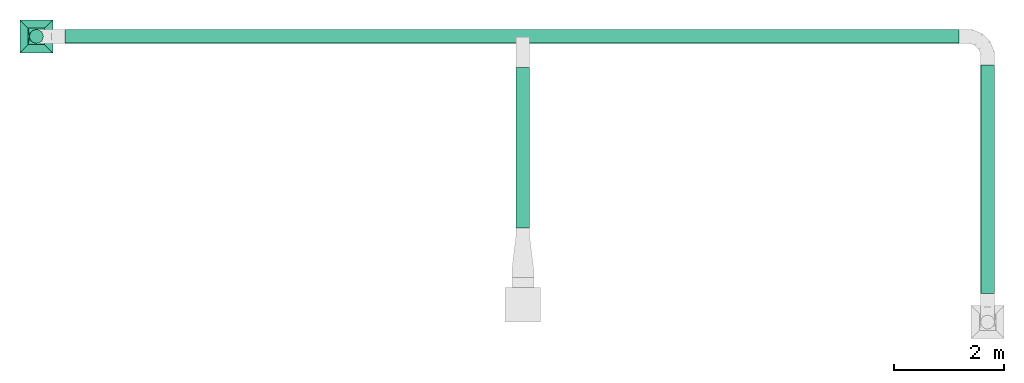
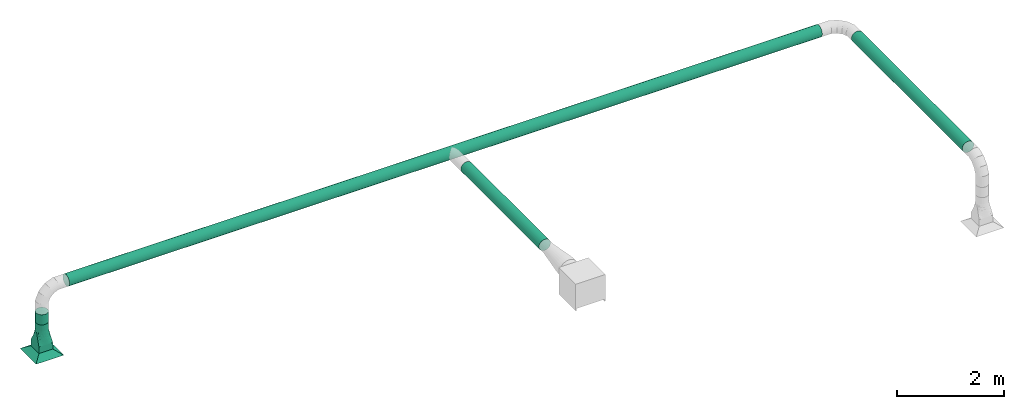
# One storey, part 1 of 6: 4 flow segments, 1 flow fitting, 1 flow terminal.
"""IFC2X3 building model written with IfcOpenShell, lengths in metres."""

from ifc_helpers import new_model, entity, si_unit, converted_unit, derived_unit, direction, frame, frame_2d, origin, origin_2d_with_axis, place, context, subcontext, project, spatial, circle, extrude, faceted_brep, source, transform, mapped, type_object, type_shapes, element, save


model = new_model("IFC2X3")

# Units and contexts
model_context = context("Model", 3, precision=1e-05, world=origin(), true_north=direction((6.12303176911189e-17, 1.0)))
body_context = subcontext(model_context, "Body", "Model", "MODEL_VIEW")
ifc_project = project(units=[si_unit("LENGTHUNIT", "METRE"), si_unit("AREAUNIT", "SQUARE_METRE"), si_unit("VOLUMEUNIT", "CUBIC_METRE"), converted_unit("PLANEANGLEUNIT", "DEGREE", entity("IfcRatioMeasure", 0.0174532925199433), si_unit("PLANEANGLEUNIT", "RADIAN"), dimensions=[0, 0, 0, 0, 0, 0, 0]), si_unit("MASSUNIT", "GRAM", prefix="KILO"), derived_unit("MASSDENSITYUNIT", [(si_unit("MASSUNIT", "GRAM", prefix="KILO"), 1), (si_unit("LENGTHUNIT", "METRE"), -3)]), si_unit("TIMEUNIT", "SECOND"), si_unit("FREQUENCYUNIT", "HERTZ"), si_unit("THERMODYNAMICTEMPERATUREUNIT", "DEGREE_CELSIUS"), derived_unit("THERMALTRANSMITTANCEUNIT", [(si_unit("MASSUNIT", "GRAM", prefix="KILO"), 1), (si_unit("THERMODYNAMICTEMPERATUREUNIT", "KELVIN"), -1), (si_unit("TIMEUNIT", "SECOND"), -3)]), derived_unit("VOLUMETRICFLOWRATEUNIT", [(si_unit("LENGTHUNIT", "METRE"), 3), (si_unit("TIMEUNIT", "SECOND"), -1)]), si_unit("ELECTRICCURRENTUNIT", "AMPERE"), si_unit("ELECTRICVOLTAGEUNIT", "VOLT"), si_unit("POWERUNIT", "WATT"), si_unit("FORCEUNIT", "NEWTON", prefix="KILO"), si_unit("ILLUMINANCEUNIT", "LUX"), si_unit("LUMINOUSFLUXUNIT", "LUMEN"), si_unit("LUMINOUSINTENSITYUNIT", "CANDELA"), derived_unit("USERDEFINED", [(si_unit("MASSUNIT", "GRAM", prefix="KILO"), -1), (si_unit("LENGTHUNIT", "METRE"), -2), (si_unit("TIMEUNIT", "SECOND"), 3), (si_unit("LUMINOUSFLUXUNIT", "LUMEN"), 1)]), derived_unit("LINEARVELOCITYUNIT", [(si_unit("LENGTHUNIT", "METRE"), 1), (si_unit("TIMEUNIT", "SECOND"), -1)]), si_unit("PRESSUREUNIT", "PASCAL"), derived_unit("USERDEFINED", [(si_unit("LENGTHUNIT", "METRE"), -2), (si_unit("MASSUNIT", "GRAM", prefix="KILO"), 1), (si_unit("TIMEUNIT", "SECOND"), -2)])], contexts=[model_context])

# Site, building, storey
site_placement = place(None, origin())
site = spatial("IfcSite", under=ifc_project, at=site_placement, CompositionType="ELEMENT")
building_placement = place(site_placement, origin())
building = spatial("IfcBuilding", under=site, at=building_placement, CompositionType="ELEMENT")
storey_placement = place(building_placement, origin())
storey = spatial("IfcBuildingStorey", under=building, at=storey_placement, Name="1 - RDC", CompositionType="ELEMENT", Elevation=1.94210219716249e-13)

# Flow terminal
air_terminal_type = type_object("IfcAirTerminalType", PredefinedType="NOTDEFINED")
shared_shape_1 = source(origin(), body_context, "Body", "Brep", [
    faceted_brep([(0.15, 0.15, 0.1016), (-0.15, 0.15, 0.1016), (-0.15, -0.15, 0.1016), (0.15, -0.15, 0.1016), (0.3, 0.3, 0.0), (0.3, -0.3, 0.0), (-0.3, -0.3, 0.0), (-0.3, 0.3, 0.0)], [[[0, 1, 2, 3]], [[4, 5, 6, 7]], [[4, 7, 1, 0]], [[7, 6, 2, 1]], [[6, 5, 3, 2]], [[5, 4, 0, 3]]]),
])
type_shapes(air_terminal_type, [shared_shape_1])
flow_terminal_placement = place(storey_placement, frame((-3.07727852654554, 0.822480211210849, 2.5)))
element("IfcFlowTerminal", 1, at=flow_terminal_placement, inside=storey, type_object=air_terminal_type, context=body_context, shape_type="MappedRepresentation", body=[
    mapped(shared_shape_1, transform((0.0, 0.0, 0.0), scale=1.0)),
])

# Flow segments
duct_segment_type = type_object("IfcDuctSegmentType", PredefinedType="NOTDEFINED")
flow_segment_1_placement = place(storey_placement, origin())
element("IfcFlowSegment", 2, at=flow_segment_1_placement, inside=storey, type_object=duct_segment_type, context=body_context, shape_type="SweptSolid", body=[
    extrude(circle(Radius=0.125, at=frame_2d((0.0, -1.35358391162299e-16), x_axis=(1.0, 0.0))), frame((-3.07727852654554, 0.822480211210858, 3.2016), z_axis=(0.0, 0.0, 1.0), x_axis=(-1.0, 0.0, 0.0)), (0.0, 0.0, 1.0), 0.232399999999998),
])
flow_segment_2_placement = place(storey_placement, origin())
element("IfcFlowSegment", 3, at=flow_segment_2_placement, inside=storey, type_object=duct_segment_type, context=body_context, shape_type="SweptSolid", body=[
    extrude(circle(Radius=0.125, at=origin_2d_with_axis()), frame((14.2727214734544, -3.8625197887892, 3.959), z_axis=(0.0, 1.0, 0.0), x_axis=(1.0, 0.0, 0.0)), (0.0, 0.0, 1.0), 4.16000000000005),
])
flow_segment_3_placement = place(storey_placement, origin())
element("IfcFlowSegment", 4, at=flow_segment_3_placement, inside=storey, type_object=duct_segment_type, context=body_context, shape_type="SweptSolid", body=[
    extrude(circle(Radius=0.125, at=frame_2d((2.70716782324598e-16, 0.0), x_axis=(1.0, 0.0))), frame((-2.55227852654554, 0.822480211210849, 3.959), z_axis=(1.0, 0.0, 0.0), x_axis=(0.0, -1.0, 0.0)), (0.0, 0.0, 1.0), 16.3),
])
flow_segment_4_placement = place(storey_placement, origin())
element("IfcFlowSegment", 5, at=flow_segment_4_placement, inside=storey, type_object=duct_segment_type, context=body_context, shape_type="SweptSolid", body=[
    extrude(circle(Radius=0.125, at=frame_2d((3.24860138789518e-15, -5.41433564649196e-16), x_axis=(1.0, 0.0))), frame((5.79472147345445, -2.66931978878916, 3.959), z_axis=(0.0, 1.0, 0.0), x_axis=(-1.0, 0.0, 0.0)), (0.0, 0.0, 1.0), 2.92977500000001),
])

# Flow fitting
duct_fitting_type = type_object("IfcDuctFittingType", Name="Standard", PredefinedType="NOTDEFINED")
shared_shape_2 = source(origin(), body_context, "Body", "Brep", [
    faceted_brep([(0.6, 0.0323523806378222, -0.120740728286125), (0.6, 0.0625000000000071, -0.108253175473047), (0.6, 0.0883883476483257, -0.0883883476483103), (0.6, 0.108253175473062, -0.062499999999992), (0.6, 0.120740728286141, -0.0323523806378072), (0.6, 0.125000000000008, 0.0), (0.6, 0.120740728286141, 0.0323523806378237), (0.6, 0.108253175473063, 0.0625000000000085), (0.6, 0.0883883476483262, 0.088388347648327), (0.6, 0.0625000000000078, 0.108253175473063), (0.6, 0.032352380637823, 0.120740728286142), (0.6, 0.0, 0.125000000000009), (0.6, -0.0323523806378072, 0.120740728286142), (0.6, -0.0624999999999921, 0.108253175473064), (0.6, -0.0883883476483105, 0.0883883476483273), (0.6, -0.108253175473047, 0.0625000000000089), (0.6, -0.120740728286126, 0.0323523806378241), (0.6, -0.124999999999992, 0.0), (0.6, -0.120740728286126, -0.0323523806378061), (0.6, -0.108253175473047, -0.062499999999991), (0.6, -0.0883883476483111, -0.0883883476483095), (0.6, -0.0624999999999927, -0.108253175473046), (0.6, -0.0323523806378079, -0.120740728286125), (0.6, 0.0, -0.124999999999991), (0.45, 0.032352380637823, 0.120740728286142), (0.45, 0.0625000000000078, 0.108253175473063), (0.45, 0.0883883476483262, 0.088388347648327), (0.45, 0.108253175473063, 0.0625000000000085), (0.45, 0.120740728286141, 0.0323523806378237), (0.45, 0.125000000000008, 0.0), (0.45, 0.120740728286141, -0.0323523806378072), (0.45, 0.108253175473062, -0.062499999999992), (0.45, 0.0883883476483257, -0.0883883476483103), (0.45, 0.0625000000000071, -0.108253175473047), (0.45, 0.0323523806378222, -0.120740728286125), (0.45, 0.0, -0.124999999999991), (0.45, -0.0323523806378079, -0.120740728286125), (0.45, -0.0624999999999927, -0.108253175473046), (0.45, -0.0883883476483111, -0.0883883476483095), (0.45, -0.108253175473047, -0.062499999999991), (0.45, -0.120740728286126, -0.0323523806378061), (0.45, -0.124999999999992, 0.0), (0.45, -0.120740728286126, 0.0323523806378241), (0.45, -0.108253175473047, 0.0625000000000089), (0.45, -0.0883883476483105, 0.0883883476483273), (0.45, -0.0624999999999921, 0.108253175473064), (0.45, -0.0323523806378072, 0.120740728286142), (0.45, 0.0, 0.125000000000009)], [[[0, 1, 2, 3, 4, 5, 6, 7, 8, 9, 10, 11, 12, 13, 14, 15, 16, 17, 18, 19, 20, 21, 22, 23]], [[24, 25, 26, 27, 28, 29, 30, 31, 32, 33, 34, 35, 36, 37, 38, 39, 40, 41, 42, 43, 44, 45, 46, 47]], [[18, 40, 39, 19]], [[38, 20, 19, 39]], [[21, 37, 36, 22]], [[38, 37, 21, 20]], [[22, 36, 35, 23]], [[40, 18, 17, 41]], [[0, 34, 33, 1]], [[32, 2, 1, 33]], [[3, 31, 30, 4]], [[32, 31, 3, 2]], [[4, 30, 29, 5]], [[34, 0, 23, 35]], [[6, 5, 29, 28]], [[7, 6, 28, 27]], [[9, 25, 24, 10]], [[47, 11, 10, 24]], [[26, 8, 7, 27]], [[26, 25, 9, 8]], [[12, 46, 45, 13]], [[44, 14, 13, 45]], [[15, 43, 42, 16]], [[44, 43, 15, 14]], [[16, 42, 41, 17]], [[46, 12, 11, 47]]]),
    faceted_brep([(0.15, -0.15, 0.150000000000001), (0.15, -0.15, -0.149999999999999), (0.15, 0.149999999999999, -0.149999999999999), (0.15, 0.149999999999999, 0.150000000000001), (0.0, -0.15, 0.150000000000001), (0.0, 0.149999999999999, 0.150000000000001), (0.0, 0.149999999999999, -0.149999999999999), (0.0, -0.15, -0.149999999999999)], [[[0, 1, 2, 3]], [[4, 5, 6, 7]], [[1, 0, 4, 7]], [[2, 1, 7, 6]], [[3, 2, 6, 5]], [[0, 3, 5, 4]]]),
    faceted_brep([(0.45, 0.0, 0.125000000000009), (0.45, -0.0386271242968605, 0.118882064536903), (0.45, -0.0734731565365512, 0.101127124296877), (0.45, -0.101127124296861, 0.073473156536568), (0.45, -0.118882064536886, 0.0386271242968774), (0.45, -0.124999999999992, 0.0), (0.45, -0.118882064536887, -0.0386271242968595), (0.45, -0.101127124296861, -0.0734731565365502), (0.45, -0.0734731565365518, -0.10112712429686), (0.45, -0.0386271242968613, -0.118882064536885), (0.45, 0.0, -0.124999999999991), (0.45, 0.0386271242968755, -0.118882064536886), (0.45, 0.0734731565365663, -0.10112712429686), (0.45, 0.101127124296876, -0.0734731565365511), (0.45, 0.118882064536902, -0.0386271242968606), (0.45, 0.125000000000008, 0.0), (0.45, 0.118882064536902, 0.038627124296877), (0.45, 0.101127124296876, 0.0734731565365677), (0.45, 0.0734731565365669, 0.101127124296877), (0.45, 0.0386271242968763, 0.118882064536903), (0.15, 0.149999999999999, -0.149999999999999), (0.15, 0.109961175269853, -0.149999999999999), (0.15, 0.0699223505397056, -0.149999999999999), (0.15, 0.0298835258095585, -0.149999999999999), (0.15, -0.0101552989205884, -0.149999999999999), (0.15, -0.0451164741904414, -0.149999999999999), (0.15, -0.0800776494602944, -0.149999999999999), (0.15, -0.115038824730147, -0.149999999999999), (0.15, -0.15, -0.149999999999999), (0.15, -0.15, 0.150000000000001), (0.15, -0.109961175269853, 0.150000000000001), (0.15, -0.0699223505397063, 0.150000000000001), (0.15, -0.0298835258095593, 0.150000000000001), (0.15, 0.0101552989205878, 0.150000000000001), (0.15, 0.0451164741904407, 0.150000000000001), (0.15, 0.0800776494602936, 0.150000000000001), (0.15, 0.115038824730147, 0.150000000000001), (0.15, 0.149999999999999, 0.150000000000001), (0.185675806788791, -0.147027016100933, -0.132162096605603), (0.228648386422417, -0.14344596779813, -0.110675806788788), (0.267972579633625, -0.140168951697195, -0.0910137101831831), (0.307296772844835, -0.13689193559626, -0.0713516135775775), (0.342972579633627, -0.133918951697193, -0.0535137101831806), (0.378648386422417, -0.130945967798126, -0.0356758067887842), (0.414324193211208, -0.127972983899059, -0.0178379033943879), (0.414324183016787, -0.127972984748594, 0.0178379084916147), (0.37864838631433, -0.130945967807133, 0.0356758068428423), (0.342972569331116, -0.133918952555735, 0.053513715334448), (0.307296752347903, -0.136891937304338, 0.0713516238260537), (0.267972569331116, -0.140168952555737, 0.091013715334446), (0.22864838631433, -0.143445967807137, 0.110675806842838), (0.189324203297543, -0.146722983058537, 0.130337898351231), (0.407779426863444, -0.05509534473452, -0.116811597641384), (0.420565846065319, -0.0870747690980912, -0.0944333005042857), (0.37492063615484, -0.0850377294350482, -0.103807552119239), (0.407779424997341, -0.110478517630006, -0.069872535353113), (0.414324203297543, 0.127972983058545, -0.0178378983512216), (0.325012046694359, -0.0717303187290657, -0.119748977707757), (0.312975795993598, -0.0174741475012942, -0.135582640240139), (0.361008549137171, -0.0338180206764952, -0.128640756913836), (0.41881495601553, 0.0160390158069551, -0.12662598048584), (0.277979222904299, -0.0543876326753398, -0.132438162718547), (0.412166085849056, 0.0552671391842867, -0.11624682673834), (0.385174825807102, 0.0185702013326801, -0.129195683593748), (0.35023235736211, 0.00695757257286128, -0.133161687370925), (0.378285465332651, 0.0568677092987935, -0.119395582892139), (0.189324183016787, 0.146722984748602, -0.130337908491605), (0.193314032806637, 0.107047065091144, -0.136334013163501), (0.373930631518513, -0.1120249018076, -0.0774763040236562), (0.340077999210493, -0.113777785509305, -0.0859517180586173), (0.32812114214319, 0.0395079399030371, -0.130543506310971), (0.283274024599807, 0.0232474382556584, -0.137616424350876), (0.397399320539831, 0.0845002566519246, -0.100424648172396), (0.358946611920716, 0.0843248469552261, -0.107088170421505), (0.401189676220562, 0.110338468230205, -0.0719208742616482), (0.310037819927421, 0.0854873259020617, -0.115364435150938), (0.337379459802237, 0.116271032149025, -0.0840484970713062), (0.399944164229103, -0.0172325795277494, -0.128094264925727), (0.370642967467547, 0.118166417987706, -0.0697060329600357), (0.278791702813727, -0.0176437263232622, -0.138551805429461), (0.205756583217155, 0.0540737656971674, -0.142029911334702), (0.239258535419748, 0.0426900256803068, -0.139426146678018), (0.202394234496035, 0.0150670252485317, -0.145389249231808), (0.211470987726484, -0.106286526921949, -0.130897710850366), (0.249109077485942, -0.0974095542101352, -0.123271105363797), (0.287665148067941, -0.104848365562891, -0.109186455477128), (0.178613678791047, -0.0984225266329105, -0.141916378681063), (0.23000520557385, -0.0640766997130127, -0.136868303383999), (0.247831393765059, -0.0326257698549697, -0.139875142969508), (0.199496898728352, -0.0242636609254632, -0.145273067572237), (0.239369440480427, 0.00487437173411708, -0.14251186564137), (0.262708817838518, 0.0710709365734255, -0.129851624011797), (0.248310480327612, 0.11051697548682, -0.117900556909347), (0.299858839780963, 0.115061209181413, -0.098096704942714), (0.267972589611872, 0.14016895086568, -0.0910137051940602), (0.307296772628659, 0.136891935614282, -0.0713516136856659), (0.22864838631433, 0.143445967807141, -0.110675806842832), (0.342972569331116, 0.133918952555745, -0.0535137153344365), (0.37864838631433, 0.130945967807145, -0.035675806842829), (0.188077660394615, -0.0644584168832844, -0.143524793783479), (0.185675806788792, 0.147027016100934, 0.132162096605606), (0.228648386422418, 0.143445967798133, 0.110675806788794), (0.267972579633626, 0.140168951697201, 0.0910137101831911), (0.307296772844835, 0.136891935596268, 0.0713516135775875), (0.342972579633627, 0.133918951697203, 0.0535137101831925), (0.378648386422418, 0.130945967798138, 0.0356758067887981), (0.414324193211208, 0.127972983899073, 0.0178379033944036), (0.407779426863444, 0.0550953447345328, 0.116811597641399), (0.420565846065319, 0.0870747690981048, 0.0944333005043017), (0.37492063615484, 0.0850377294350594, 0.103807552119252), (0.407779424997341, 0.110478517630019, 0.0698725353531284), (0.325012046694359, 0.0717303187290742, 0.119748977707768), (0.312975795993598, 0.017474147501302, 0.13558264024015), (0.361008549137171, 0.0338180206765055, 0.128640756913849), (0.41881495601553, -0.0160390158069417, 0.126625980485855), (0.277979222904299, 0.0543876326753458, 0.132438162718555), (0.412166085849056, -0.0552671391842736, 0.116246826738355), (0.385174825807102, -0.0185702013326686, 0.129195683593762), (0.35023235736211, -0.00695757257285159, 0.133161687370937), (0.378285465332651, -0.0568677092987823, 0.119395582892152), (0.193314032806637, -0.107047065091143, 0.136334013163505), (0.373930631518513, 0.112024901807611, 0.0774763040236699), (0.340077999210493, 0.113777785509314, 0.0859517180586292), (0.32812114214319, -0.0395079399030286, 0.130543506310982), (0.283274024599807, -0.023247438255652, 0.137616424350885), (0.397399320539831, -0.0845002566519122, 0.10042464817241), (0.358946611920716, -0.0843248469552158, 0.107088170421517), (0.401189676220562, -0.110338468230192, 0.0719208742616627), (0.310037819927421, -0.0854873259020542, 0.115364435150948), (0.337379459802237, -0.116271032149016, 0.0840484970713174), (0.399944164229103, 0.0172325795277618, 0.128094264925742), (0.370642967467547, -0.118166417987695, 0.0697060329600486), (0.278791702813727, 0.0176437263232682, 0.138551805429469), (0.205756583217155, -0.0540737656971653, 0.142029911334707), (0.239258535419748, -0.042690025680303, 0.139426146678024), (0.202394234496036, -0.0150670252485298, 0.145389249231812), (0.211470987726485, 0.106286526921951, 0.130897710850371), (0.249109077485942, 0.0974095542101395, 0.123271105363805), (0.287665148067941, 0.104848365562898, 0.109186455477138), (0.178613678791047, 0.0984225266329113, 0.141916378681066), (0.23000520557385, 0.0640766997130158, 0.136868303384005), (0.24783139376506, 0.0326257698549739, 0.139875142969515), (0.199496898728352, 0.0242636609254647, 0.145273067572242), (0.239369440480428, -0.00487437173411328, 0.142511865641377), (0.262708817838518, -0.0710709365734204, 0.129851624011805), (0.248310480327612, -0.110516975486815, 0.117900556909354), (0.299858839780963, -0.115061209181406, 0.0980967049427232), (0.188077660394615, 0.0644584168832854, 0.143524793783483)], [[[0, 1, 2, 3, 4, 5, 6, 7, 8, 9, 10, 11, 12, 13, 14, 15, 16, 17, 18, 19]], [[20, 21, 22, 23, 24, 25, 26, 27, 28, 29, 30, 31, 32, 33, 34, 35, 36, 37]], [[29, 28, 38, 39, 40, 41, 42, 43, 44, 5, 45, 46, 47, 48, 49, 50, 51]], [[52, 53, 54]], [[7, 6, 55]], [[15, 14, 56]], [[57, 58, 59]], [[10, 60, 11]], [[9, 8, 52]], [[58, 57, 61]], [[6, 44, 55]], [[62, 60, 63]], [[64, 65, 63]], [[21, 66, 67]], [[68, 42, 69]], [[70, 58, 71]], [[72, 13, 12]], [[73, 65, 70]], [[14, 13, 74]], [[8, 7, 53]], [[11, 62, 12]], [[75, 76, 73]], [[70, 75, 73]], [[52, 77, 9]], [[55, 53, 7]], [[56, 14, 74]], [[52, 54, 59]], [[72, 12, 62]], [[78, 73, 76]], [[54, 53, 55]], [[54, 68, 69]], [[54, 57, 59]], [[77, 63, 60]], [[63, 65, 62]], [[62, 65, 72]], [[64, 58, 70]], [[77, 59, 63]], [[58, 61, 79]], [[80, 81, 82]], [[54, 69, 57]], [[39, 83, 84]], [[69, 41, 85]], [[27, 26, 86]], [[54, 55, 68]], [[39, 84, 40]], [[55, 43, 68]], [[57, 69, 85]], [[85, 84, 61]], [[85, 61, 57]], [[61, 87, 88]], [[89, 90, 88]], [[81, 80, 91]], [[89, 82, 90]], [[80, 67, 92]], [[91, 92, 93]], [[67, 80, 22]], [[67, 22, 21]], [[94, 95, 93]], [[63, 59, 64]], [[72, 73, 74]], [[88, 79, 61]], [[70, 71, 75]], [[73, 72, 65]], [[13, 72, 74]], [[92, 96, 94]], [[75, 93, 76]], [[92, 67, 96]], [[93, 95, 76]], [[92, 91, 80]], [[76, 95, 97]], [[74, 78, 98]], [[81, 71, 90]], [[75, 71, 91]], [[11, 60, 62]], [[10, 9, 77]], [[77, 60, 10]], [[59, 77, 52]], [[91, 93, 75]], [[94, 93, 92]], [[74, 98, 56]], [[44, 6, 5]], [[44, 43, 55]], [[8, 53, 52]], [[38, 28, 27]], [[66, 21, 20]], [[25, 89, 99]], [[85, 41, 40]], [[42, 68, 43]], [[42, 41, 69]], [[89, 88, 87]], [[79, 90, 71]], [[99, 89, 87]], [[23, 82, 24]], [[90, 79, 88]], [[71, 58, 79]], [[99, 86, 26]], [[25, 24, 89]], [[83, 99, 87]], [[84, 83, 87]], [[38, 83, 39]], [[86, 99, 83]], [[27, 86, 38]], [[38, 86, 83]], [[99, 26, 25]], [[80, 23, 22]], [[61, 84, 87]], [[40, 84, 85]], [[71, 81, 91]], [[82, 81, 90]], [[58, 64, 59]], [[66, 96, 67]], [[65, 64, 70]], [[73, 78, 74]], [[78, 97, 98]], [[97, 78, 76]], [[24, 82, 89]], [[23, 80, 82]], [[56, 98, 97, 95, 94, 96, 66, 20, 37, 100, 101, 102, 103, 104, 105, 106, 15]], [[107, 108, 109]], [[17, 16, 110]], [[5, 4, 45]], [[111, 112, 113]], [[0, 114, 1]], [[19, 18, 107]], [[112, 111, 115]], [[16, 106, 110]], [[116, 114, 117]], [[118, 119, 117]], [[30, 51, 120]], [[121, 104, 122]], [[123, 112, 124]], [[125, 3, 2]], [[126, 119, 123]], [[4, 3, 127]], [[18, 17, 108]], [[1, 116, 2]], [[128, 129, 126]], [[123, 128, 126]], [[107, 130, 19]], [[110, 108, 17]], [[45, 4, 127]], [[107, 109, 113]], [[125, 2, 116]], [[131, 126, 129]], [[109, 108, 110]], [[109, 121, 122]], [[109, 111, 113]], [[130, 117, 114]], [[117, 119, 116]], [[116, 119, 125]], [[118, 112, 123]], [[130, 113, 117]], [[112, 115, 132]], [[133, 134, 135]], [[109, 122, 111]], [[101, 136, 137]], [[122, 103, 138]], [[36, 35, 139]], [[109, 110, 121]], [[101, 137, 102]], [[110, 105, 121]], [[111, 122, 138]], [[138, 137, 115]], [[138, 115, 111]], [[115, 140, 141]], [[142, 143, 141]], [[134, 133, 144]], [[142, 135, 143]], [[133, 120, 145]], [[144, 145, 146]], [[120, 133, 31]], [[120, 31, 30]], [[49, 48, 146]], [[117, 113, 118]], [[125, 126, 127]], [[141, 132, 115]], [[123, 124, 128]], [[126, 125, 119]], [[3, 125, 127]], [[145, 50, 49]], [[128, 146, 129]], [[145, 120, 50]], [[146, 48, 129]], [[145, 144, 133]], [[129, 48, 47]], [[127, 131, 46]], [[134, 124, 143]], [[128, 124, 144]], [[1, 114, 116]], [[0, 19, 130]], [[130, 114, 0]], [[113, 130, 107]], [[144, 146, 128]], [[49, 146, 145]], [[127, 46, 45]], [[106, 16, 15]], [[106, 105, 110]], [[18, 108, 107]], [[100, 37, 36]], [[51, 30, 29]], [[34, 142, 147]], [[138, 103, 102]], [[104, 121, 105]], [[104, 103, 122]], [[142, 141, 140]], [[132, 143, 124]], [[147, 142, 140]], [[32, 135, 33]], [[143, 132, 141]], [[124, 112, 132]], [[147, 139, 35]], [[34, 33, 142]], [[136, 147, 140]], [[137, 136, 140]], [[100, 136, 101]], [[139, 147, 136]], [[36, 139, 100]], [[100, 139, 136]], [[147, 35, 34]], [[133, 32, 31]], [[115, 137, 140]], [[102, 137, 138]], [[124, 134, 144]], [[135, 134, 143]], [[112, 118, 113]], [[51, 50, 120]], [[119, 118, 123]], [[126, 131, 127]], [[131, 47, 46]], [[47, 131, 129]], [[33, 135, 142]], [[32, 133, 135]]]),
])
type_shapes(duct_fitting_type, [shared_shape_2])
flow_fitting_placement = place(storey_placement, frame((-3.07727852654554, 0.822480211210849, 2.6016), z_axis=(0.0, 1.0, 0.0), x_axis=(0.0, 0.0, 1.0)))
element("IfcFlowFitting", 6, at=flow_fitting_placement, inside=storey, type_object=duct_fitting_type, ObjectType="Standard", context=body_context, shape_type="MappedRepresentation", body=[
    mapped(shared_shape_2, transform((0.0, 0.0, 0.0), scale=1.0)),
])

save(model, "model.ifc")
